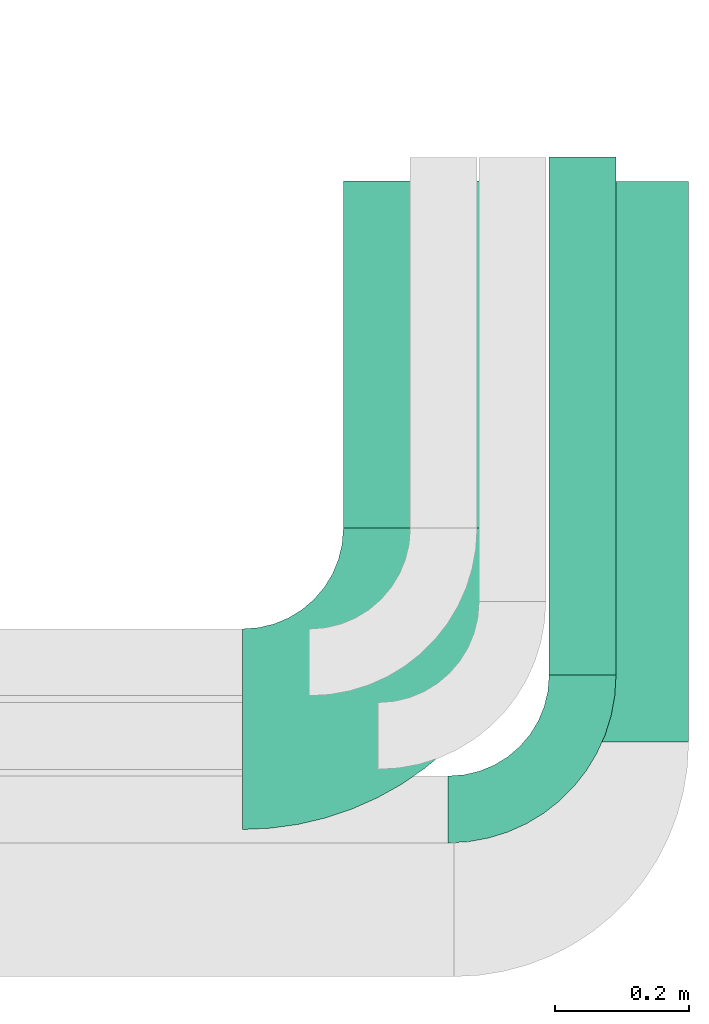
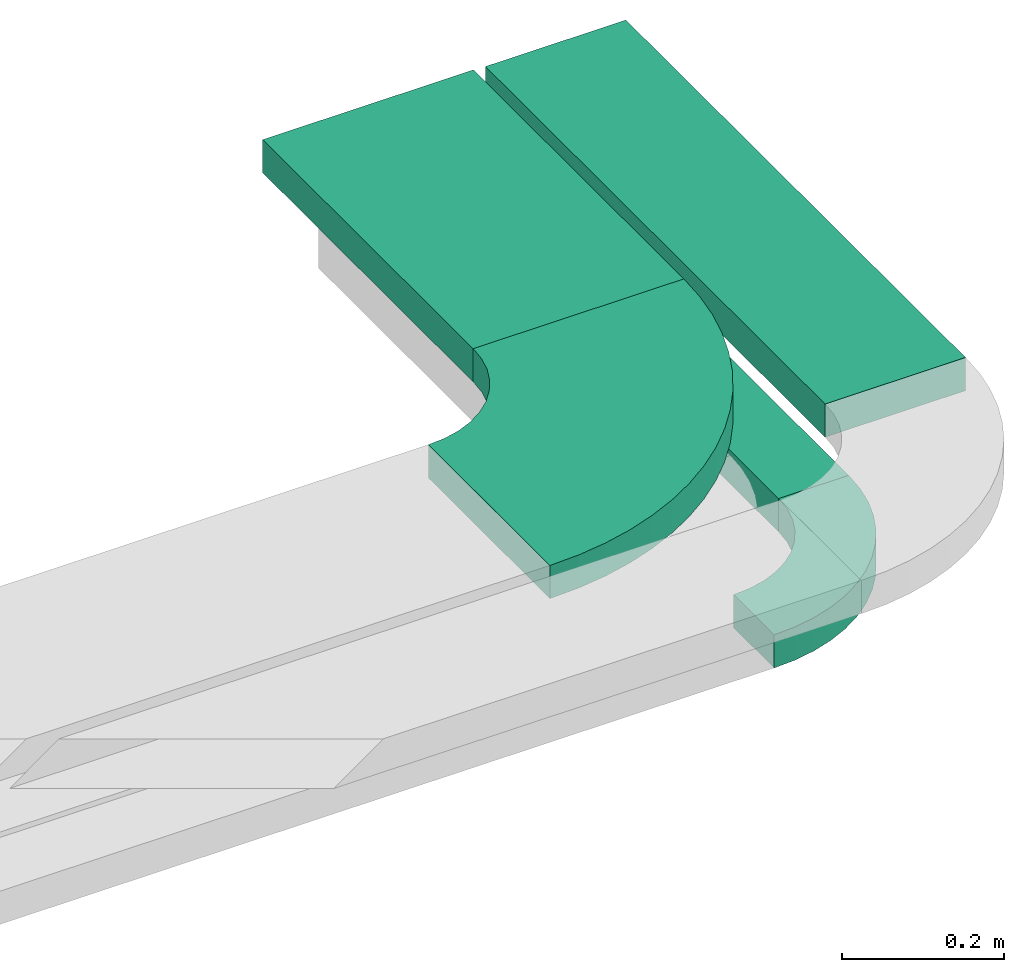
# One storey, part 18 of 19: 3 flow segments, 2 flow fittings.
"""IFC2X3 building model written with IfcOpenShell, lengths in millimetres."""

from ifc_helpers import new_model, entity, si_unit, converted_unit, derived_unit, direction, frame, frame_2d, origin, origin_2d_with_axis, place, context, subcontext, project, spatial, polyline, circle_curve, parameter, trimmed, segment, composite_curve, rectangle, outline, extrude, source, transform, mapped, material, type_object, type_shapes, element, save


model = new_model("IFC2X3")

# Units and contexts
model_context = context("Model", 3, precision=0.01, world=origin(), true_north=direction((6.12303176911189e-17, 1.0)))
body_context = subcontext(model_context, "Body", "Model", "MODEL_VIEW")
ifc_project = project(units=[si_unit("LENGTHUNIT", "METRE", prefix="MILLI"), si_unit("AREAUNIT", "SQUARE_METRE"), si_unit("VOLUMEUNIT", "CUBIC_METRE"), converted_unit("PLANEANGLEUNIT", "DEGREE", entity("IfcRatioMeasure", 0.0174532925199433), si_unit("PLANEANGLEUNIT", "RADIAN"), dimensions=[0, 0, 0, 0, 0, 0, 0]), si_unit("MASSUNIT", "GRAM", prefix="KILO"), derived_unit("MASSDENSITYUNIT", [(si_unit("MASSUNIT", "GRAM", prefix="KILO"), 1), (si_unit("LENGTHUNIT", "METRE"), -3)]), derived_unit("MOMENTOFINERTIAUNIT", [(si_unit("LENGTHUNIT", "METRE"), 4)]), si_unit("TIMEUNIT", "SECOND"), si_unit("FREQUENCYUNIT", "HERTZ"), si_unit("THERMODYNAMICTEMPERATUREUNIT", "DEGREE_CELSIUS"), derived_unit("THERMALTRANSMITTANCEUNIT", [(si_unit("MASSUNIT", "GRAM", prefix="KILO"), 1), (si_unit("THERMODYNAMICTEMPERATUREUNIT", "KELVIN"), -1), (si_unit("TIMEUNIT", "SECOND"), -3)]), derived_unit("VOLUMETRICFLOWRATEUNIT", [(si_unit("LENGTHUNIT", "METRE"), 3), (si_unit("TIMEUNIT", "SECOND"), -1)]), derived_unit("MASSFLOWRATEUNIT", [(si_unit("MASSUNIT", "GRAM", prefix="KILO"), 1), (si_unit("TIMEUNIT", "SECOND"), -1)]), derived_unit("ROTATIONALFREQUENCYUNIT", [(si_unit("TIMEUNIT", "SECOND"), -1)]), si_unit("ELECTRICCURRENTUNIT", "AMPERE"), si_unit("ELECTRICVOLTAGEUNIT", "VOLT"), si_unit("POWERUNIT", "WATT"), si_unit("FORCEUNIT", "NEWTON", prefix="KILO"), si_unit("ILLUMINANCEUNIT", "LUX"), si_unit("LUMINOUSFLUXUNIT", "LUMEN"), si_unit("LUMINOUSINTENSITYUNIT", "CANDELA"), derived_unit("USERDEFINED", [(si_unit("MASSUNIT", "GRAM", prefix="KILO"), -1), (si_unit("LENGTHUNIT", "METRE"), -2), (si_unit("TIMEUNIT", "SECOND"), 3), (si_unit("LUMINOUSFLUXUNIT", "LUMEN"), 1)]), derived_unit("LINEARVELOCITYUNIT", [(si_unit("LENGTHUNIT", "METRE"), 1), (si_unit("TIMEUNIT", "SECOND"), -1)]), si_unit("PRESSUREUNIT", "PASCAL"), derived_unit("USERDEFINED", [(si_unit("LENGTHUNIT", "METRE"), -2), (si_unit("MASSUNIT", "GRAM", prefix="KILO"), 1), (si_unit("TIMEUNIT", "SECOND"), -2)]), derived_unit("LINEARFORCEUNIT", [(si_unit("MASSUNIT", "GRAM", prefix="KILO"), 1), (si_unit("LENGTHUNIT", "METRE"), 1), (si_unit("TIMEUNIT", "SECOND"), -2), (si_unit("LENGTHUNIT", "METRE"), -1)]), derived_unit("PLANARFORCEUNIT", [(si_unit("MASSUNIT", "GRAM", prefix="KILO"), 1), (si_unit("LENGTHUNIT", "METRE"), 1), (si_unit("TIMEUNIT", "SECOND"), -2), (si_unit("LENGTHUNIT", "METRE"), -2)])], contexts=[model_context])

# Site, building, storey
site_placement = place(None, frame((0.0, -0.00077364408347762, 0.0)))
site = spatial("IfcSite", under=ifc_project, at=site_placement, CompositionType="ELEMENT")
building_placement = place(site_placement, origin())
building = spatial("IfcBuilding", under=site, at=building_placement, CompositionType="ELEMENT")
storey_placement = place(building_placement, frame((0.0, 0.0, 12000.0)))
storey = spatial("IfcBuildingStorey", under=building, at=storey_placement, CompositionType="ELEMENT", Elevation=12000.0)

# Flow segments
cable_carrier_segment_type = type_object("IfcCableCarrierSegmentType", PredefinedType="CABLETRAYSEGMENT")
flow_segment_1_placement = place(storey_placement, frame((68595.205370445, 9875.98776831999, 2600.0)))
element("IfcFlowSegment", 1, at=flow_segment_1_placement, inside=storey, type_object=cable_carrier_segment_type, context=body_context, shape_type="SweptSolid", body=[
    extrude(rectangle(XDim=774.442563315416, YDim=99.9999999999946, at=frame_2d((0.0, -4.33075797445781e-12), x_axis=(1.0, 0.0))), frame((50.0, 387.221281657709, 0.0), z_axis=(0.0, 0.0, 1.0), x_axis=(0.0, 1.0, 0.0)), (0.0, 0.0, 1.0), 50.0000000000038),
])
flow_segment_2_placement = place(storey_placement, frame((68287.4951164855, 10095.98776832, 2800.0)))
element("IfcFlowSegment", 2, at=flow_segment_2_placement, inside=storey, type_object=cable_carrier_segment_type, context=body_context, shape_type="SweptSolid", body=[
    extrude(rectangle(XDim=518.999999999975, YDim=300.000000000001, at=origin_2d_with_axis()), frame((150.0, 259.499999999997, 0.0), z_axis=(0.0, 0.0, 1.0), x_axis=(0.0, 1.0, 0.0)), (0.0, 0.0, 1.0), 49.9999999999995),
])
flow_segment_3_placement = place(storey_placement, frame((68603.9467817498, 9775.98776831999, 2800.0)))
element("IfcFlowSegment", 3, at=flow_segment_3_placement, inside=storey, type_object=cable_carrier_segment_type, context=body_context, shape_type="SweptSolid", body=[
    extrude(rectangle(XDim=837.829364585167, YDim=200.000000000007, at=frame_2d((-1.08002495835535e-12, 0.0), x_axis=(1.0, 0.0))), frame((100.0, 418.914682292587, 0.0), z_axis=(0.0, 0.0, 1.0), x_axis=(0.0, 1.0, 0.0)), (0.0, 0.0, 1.0), 50.0000000000016),
])

# Flow fittings
ifc_material = material()
cable_carrier_fitting_type_1 = type_object("IfcCableCarrierFittingType", Name="470_DKC_S5_Variable Angle Elbow 0-45:-", PredefinedType="NOTDEFINED", material=ifc_material)
shared_shape_1 = source(origin(), body_context, "Body", "SweptSolid", [
    extrude(outline(composite_curve([segment(polyline([(-150.749999999996, -300.250000000003), (-149.749999999994, -300.250000000003)]), True, "CONTINUOUS"), segment(trimmed(circle_curve(frame_2d((-149.750000000002, 149.749999999997), x_axis=(0.0, -1.0)), 450.0), [parameter(0.0)], [parameter(90.0000000000001)], True, "PARAMETER"), True, "CONTINUOUS"), segment(polyline([(300.249999999997, 149.750000000005), (300.249999999997, 150.750000000004)]), True, "CONTINUOUS"), segment(polyline([(300.249999999997, 150.750000000003), (0.249999999997449, 150.750000000002)]), True, "CONTINUOUS"), segment(polyline([(0.249999999997449, 150.750000000002), (0.249999999997438, 149.75)]), True, "CONTINUOUS"), segment(trimmed(circle_curve(frame_2d((-149.750000000002, 149.749999999997), x_axis=(0.0, -1.0)), 150.0), [parameter(0.0)], [parameter(90.0000000000001)], True, "PARAMETER"), False, "CONTINUOUS"), segment(polyline([(-149.749999999999, -0.250000000002818), (-150.750000000001, -0.250000000002835)]), True, "CONTINUOUS"), segment(polyline([(-150.750000000001, -0.250000000002835), (-150.749999999996, -300.250000000003)]), True, "CONTINUOUS")], self_intersect=False)), frame((-150.249999999991, 150.249999999992, -25.0)), (0.0, 0.0, 1.0), 49.9999999999974),
])
type_shapes(cable_carrier_fitting_type_1, [shared_shape_1])
flow_fitting_1_placement = place(storey_placement, frame((68437.4951164856, 9794.98776832003, 2825.0)))
element("IfcFlowFitting", 4, at=flow_fitting_1_placement, inside=storey, type_object=cable_carrier_fitting_type_1, material=ifc_material, Name="470_DKC_S5_Variable Angle Elbow 0-45:-", ObjectType="470_DKC_S5_Variable Angle Elbow 0-45:-", context=body_context, shape_type="MappedRepresentation", body=[
    mapped(shared_shape_1, transform((0.0, 0.0, 0.0), scale=1.0)),
])
cable_carrier_fitting_type_2 = type_object("IfcCableCarrierFittingType", Name="470_DKC_S5_Variable Angle Elbow 0-45:-", PredefinedType="NOTDEFINED", material=ifc_material)
shared_shape_2 = source(origin(), body_context, "Body", "SweptSolid", [
    extrude(outline(composite_curve([segment(polyline([(-100.750000000001, -150.25), (-99.7499999999994, -150.25)]), True, "CONTINUOUS"), segment(trimmed(circle_curve(frame_2d((-99.7499999999997, 99.7499999999995), x_axis=(0.0, -1.0)), 250.0), [parameter(0.0)], [parameter(90.0000000000001)], True, "PARAMETER"), True, "CONTINUOUS"), segment(polyline([(150.25, 99.75), (150.25, 100.749999999999)]), True, "CONTINUOUS"), segment(polyline([(150.25, 100.749999999999), (50.25, 100.75)]), True, "CONTINUOUS"), segment(polyline([(50.25, 100.75), (50.25, 99.7499999999998)]), True, "CONTINUOUS"), segment(trimmed(circle_curve(frame_2d((-99.7499999999997, 99.7499999999995), x_axis=(0.0, -1.0)), 150.0), [parameter(0.0)], [parameter(90.0000000000001)], True, "PARAMETER"), False, "CONTINUOUS"), segment(polyline([(-99.7499999999994, -50.2500000000003), (-100.750000000001, -50.2500000000003)]), True, "CONTINUOUS"), segment(polyline([(-100.750000000001, -50.2500000000003), (-100.750000000001, -150.25)]), True, "CONTINUOUS")], self_intersect=False)), frame((-100.249999999991, 100.249999999992, -25.0)), (0.0, 0.0, 1.0), 49.9999999999997),
])
type_shapes(cable_carrier_fitting_type_2, [shared_shape_2])
flow_fitting_2_placement = place(storey_placement, frame((68645.205370445, 9674.98776832001, 2625.0)))
element("IfcFlowFitting", 5, at=flow_fitting_2_placement, inside=storey, type_object=cable_carrier_fitting_type_2, material=ifc_material, Name="470_DKC_S5_Variable Angle Elbow 0-45:-", ObjectType="470_DKC_S5_Variable Angle Elbow 0-45:-", context=body_context, shape_type="MappedRepresentation", body=[
    mapped(shared_shape_2, transform((0.0, 0.0, 0.0), scale=1.0)),
])

save(model, "model.ifc")
